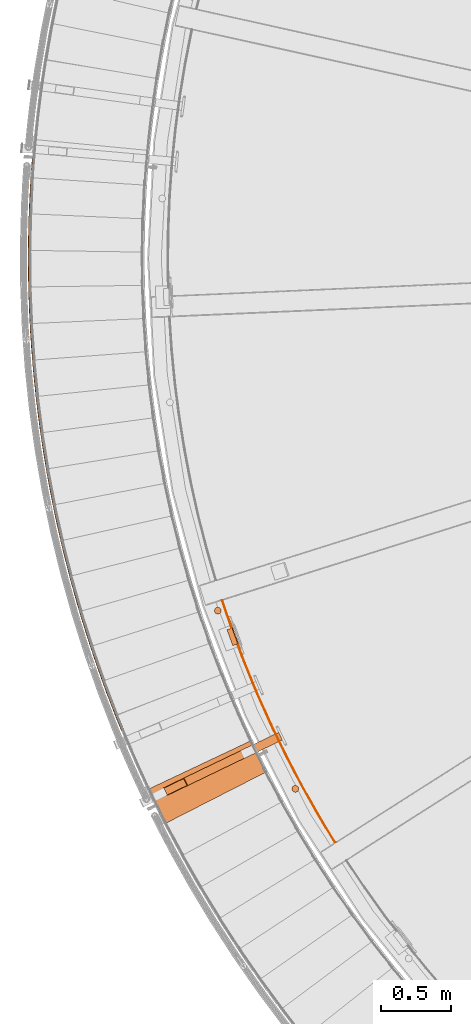
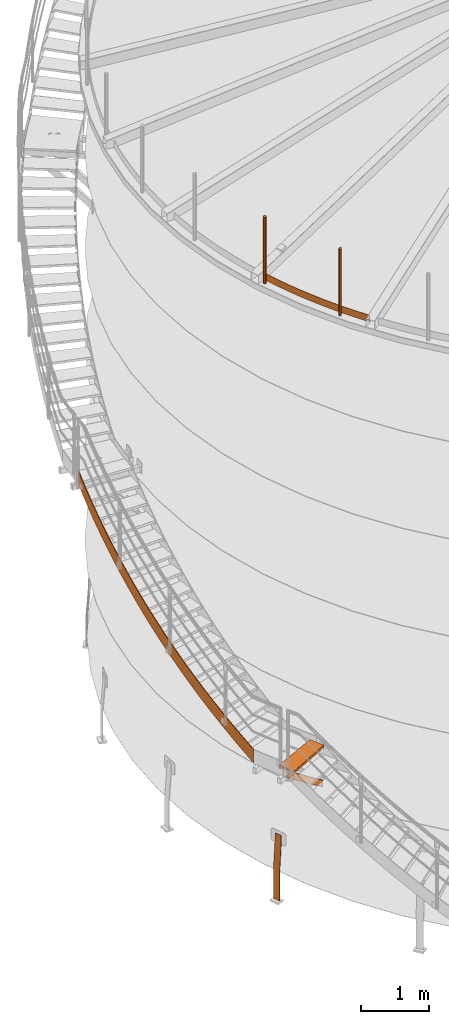
# One storey, part 10 of 126: 7 proxies.
"""IFC2X3 building model written with IfcOpenShell, lengths in millimetres."""

from ifc_helpers import new_model, si_unit, origin, origin_with_axes, place, context, project, spatial, faceted_brep, material, element, save


model = new_model("IFC2X3")

# Units and contexts
context_of_model_1 = context(None, 3, precision=0.1, world=origin())
context_of_model_2 = context(None, 3, precision=0.1, world=origin())
ifc_project = project(units=[si_unit("LENGTHUNIT", "METRE", prefix="MILLI"), si_unit("AREAUNIT", "SQUARE_METRE", prefix="CENTI"), si_unit("VOLUMEUNIT", "CUBIC_METRE", prefix="CENTI"), si_unit("MASSUNIT", "GRAM", prefix="KILO")], contexts=[context_of_model_1, context_of_model_2])

# Site, building, storey
site_placement = place(None, origin_with_axes())
site = spatial("IfcSite", under=ifc_project, at=site_placement, CompositionType="ELEMENT")
building_placement = place(site_placement, origin_with_axes())
building = spatial("IfcBuilding", under=site, at=building_placement, CompositionType="ELEMENT")
storey_placement = place(building_placement, origin_with_axes())
storey = spatial("IfcBuildingStorey", under=building, at=storey_placement, CompositionType="ELEMENT")

# Proxies
ifc_material_1 = material(Name="S235JRG2")
proxy_1_placement = place(storey_placement, origin_with_axes())
element("IfcBuildingElementProxy", 1, at=proxy_1_placement, inside=storey, material=ifc_material_1, context=context_of_model_2, shape_type="Brep", body=[
    faceted_brep([(-166.7085, 4662.1835, 2637.9555), (-157.4529, 4665.9697, 2637.8818), (-153.3509, 4656.0918, 2630.7481), (-162.2845, 4651.5301, 2630.2657), (-157.4529, 4665.9697, 2878.2856), (-153.3509, 4656.0918, 2871.1497), (-166.7085, 4662.1835, 2878.3209), (-162.2845, 4651.5301, 2870.6335), (-201.65, 4748.9075, 2700.2751), (-192.3548, 4752.5955, 2700.1807), (-192.3548, 4752.5955, 2940.5948), (-201.65, 4748.9075, 2940.6301), (-235.6711, 4835.9968, 2762.59), (-226.3373, 4839.5861, 2762.4843), (-226.3373, 4839.5861, 3002.9041), (-235.6711, 4835.9968, 3002.9394), (-268.7681, 4923.4414, 2824.9023), (-259.3968, 4926.9317, 2824.7904), (-259.3968, 4926.9317, 3065.2133), (-268.7681, 4923.4414, 3065.2486), (-300.9372, 5011.2316, 2887.2132), (-291.5295, 5014.6224, 2887.098), (-291.5295, 5014.6224, 3127.5226), (-300.9372, 5011.2316, 3127.5579), (-332.1748, 5099.3575, 2949.5234), (-322.7317, 5102.6486, 2949.4064), (-322.7317, 5102.6486, 3189.8318), (-332.1748, 5099.3575, 3189.8671), (-362.4774, 5187.8093, 3011.8331), (-353.0, 5191.0002, 3011.7151), (-353.0, 5191.0002, 3252.1411), (-362.4774, 5187.8093, 3252.1764), (-391.8416, 5276.577, 3074.1426), (-382.331, 5279.6674, 3074.0241), (-382.331, 5279.6674, 3314.4503), (-391.8416, 5276.577, 3314.4856), (-420.2642, 5365.6507, 3136.452), (-410.7213, 5368.6402, 3136.3332), (-410.7213, 5368.6402, 3376.7596), (-420.2642, 5365.6507, 3376.7949), (-447.7419, 5455.0205, 3198.7613), (-438.1679, 5457.9087, 3198.6424), (-438.1679, 5457.9087, 3439.0688), (-447.7419, 5455.0205, 3439.1041), (-474.2716, 5544.6761, 3261.0706), (-464.6676, 5547.4628, 3260.9516), (-464.6676, 5547.4628, 3501.3781), (-474.2716, 5544.6761, 3501.4134), (-499.8504, 5634.6077, 3323.3799), (-490.2175, 5637.2925, 3323.2608), (-490.2175, 5637.2925, 3563.6873), (-499.8504, 5634.6077, 3563.7226), (-524.4755, 5724.8052, 3385.6892), (-514.8146, 5727.3878, 3385.57), (-514.8146, 5727.3878, 3625.9966), (-524.4755, 5724.8052, 3626.0319), (-548.144, 5815.2583, 3447.9984), (-538.4563, 5817.7385, 3447.8793), (-538.4563, 5817.7385, 3688.3058), (-548.144, 5815.2583, 3688.3411), (-570.8532, 5905.957, 3510.3077), (-561.1398, 5908.3345, 3510.1885), (-561.1398, 5908.3345, 3750.615), (-570.8532, 5905.957, 3750.6504), (-592.6008, 5996.8911, 3572.6169), (-582.8627, 5999.1656, 3572.4978), (-582.8627, 5999.1656, 3812.9243), (-592.6008, 5996.8911, 3812.9596), (-613.3841, 6088.0505, 3634.9262), (-603.6225, 6090.2217, 3634.807), (-603.6225, 6090.2217, 3875.2335), (-613.3841, 6088.0505, 3875.2688), (-633.2009, 6179.4248, 3697.2354), (-623.4169, 6181.4925, 3697.1163), (-623.4169, 6181.4925, 3937.5428), (-633.2009, 6179.4248, 3937.5781), (-652.049, 6271.0038, 3759.5447), (-642.2436, 6272.9678, 3759.4255), (-642.2436, 6272.9678, 3999.852), (-652.049, 6271.0038, 3999.8873), (-669.9262, 6362.7773, 3821.8539), (-660.1006, 6364.6373, 3821.7347), (-660.1006, 6364.6373, 4062.1613), (-669.9262, 6362.7773, 4062.1966), (-686.8306, 6454.735, 3884.1631), (-676.9858, 6456.4909, 3884.044), (-676.9858, 6456.4909, 4124.4705), (-686.8306, 6454.735, 4124.5058), (-702.7601, 6546.8665, 3946.4724), (-692.8973, 6548.518, 3946.3532), (-692.8973, 6548.518, 4186.7798), (-702.7601, 6546.8665, 4186.8151), (-717.7132, 6639.1615, 4008.7816), (-707.8334, 6640.7085, 4008.6625), (-707.8334, 6640.7085, 4249.089), (-717.7132, 6639.1615, 4249.1243), (-731.688, 6731.6097, 4071.0909), (-721.7924, 6733.052, 4070.9717), (-721.7924, 6733.052, 4311.3983), (-731.688, 6731.6097, 4311.4336), (-744.683, 6824.2008, 4133.4001), (-734.7727, 6825.5382, 4133.281), (-734.7727, 6825.5382, 4373.7075), (-744.683, 6824.2008, 4373.7428), (-756.6968, 6916.9242, 4195.7094), (-746.7729, 6918.1566, 4195.5902), (-746.7729, 6918.1566, 4436.0168), (-756.6968, 6916.9242, 4436.0521), (-767.728, 7009.7697, 4258.0186), (-757.7916, 7010.8969, 4257.8995), (-757.7916, 7010.8969, 4498.326), (-767.728, 7009.7697, 4498.3613), (-777.7754, 7102.7268, 4320.3279), (-767.8276, 7103.7487, 4320.2087), (-767.8276, 7103.7487, 4560.6353), (-777.7754, 7102.7268, 4560.6706), (-786.8378, 7195.785, 4382.6371), (-776.8797, 7196.7016, 4382.518), (-776.8797, 7196.7016, 4622.9445), (-786.8378, 7195.785, 4622.9798), (-794.9142, 7288.9341, 4444.9464), (-784.947, 7289.7451, 4444.8272), (-784.947, 7289.7451, 4685.2538), (-794.9142, 7288.9341, 4685.2891), (-802.0037, 7382.1634, 4507.2556), (-792.0285, 7382.8688, 4507.1365), (-792.0285, 7382.8688, 4747.563), (-802.0037, 7382.1634, 4747.5983), (-808.1056, 7475.4626, 4569.5649), (-798.1235, 7476.0623, 4569.4457), (-798.1235, 7476.0623, 4809.8723), (-808.1056, 7475.4626, 4809.9076), (-813.2191, 7568.8211, 4631.8741), (-803.2312, 7569.3152, 4631.755), (-803.2312, 7569.3152, 4872.1815), (-813.2191, 7568.8211, 4872.2168), (-817.3437, 7662.2286, 4694.1834), (-807.3511, 7662.6168, 4694.0642), (-807.3511, 7662.6168, 4934.4908), (-817.3437, 7662.2286, 4934.5261), (-820.4789, 7755.6745, 4756.4926), (-810.4827, 7755.9569, 4756.3735), (-810.4827, 7755.9569, 4996.8), (-820.4789, 7755.6745, 4996.8353), (-822.6243, 7849.1484, 4818.8019), (-812.6257, 7849.3249, 4818.6827), (-812.6257, 7849.3249, 5059.1092), (-822.6243, 7849.1484, 5059.1446), (-823.7798, 7942.6397, 4881.1111), (-813.7799, 7942.7104, 4880.992), (-813.7799, 7942.7104, 5121.4185), (-823.7798, 7942.6397, 5121.4538), (-823.9451, 8036.1381, 4943.4204), (-813.945, 8036.1028, 4943.3012), (-813.945, 8036.1028, 5183.7277), (-823.9451, 8036.1381, 5183.763), (-823.1203, 8129.633, 5005.7296), (-813.1212, 8129.4918, 5005.6105), (-813.1212, 8129.4918, 5246.037), (-823.1203, 8129.633, 5246.0723), (-821.3054, 8223.1138, 5068.0389), (-811.3084, 8222.8668, 5067.9197), (-811.3084, 8222.8668, 5308.3462), (-821.3054, 8223.1138, 5308.3815), (-818.5008, 8316.5703, 5130.3481), (-808.5068, 8316.2174, 5130.2289), (-808.5068, 8316.2174, 5370.6555), (-818.5008, 8316.5703, 5370.6908), (-814.7065, 8409.9917, 5192.6573), (-804.7169, 8409.533, 5192.5382), (-804.7169, 8409.533, 5432.9647), (-814.7065, 8409.9917, 5433.0), (-809.9232, 8503.3678, 5254.9666), (-799.939, 8502.8033, 5254.8474), (-799.939, 8502.8033, 5495.274), (-809.9232, 8503.3678, 5495.3093), (-804.1514, 8596.688, 5317.2758), (-794.1737, 8596.0178, 5317.1567), (-794.1737, 8596.0178, 5557.5832), (-804.1514, 8596.688, 5557.6185), (-797.3916, 8689.9418, 5379.5851), (-787.4216, 8689.166, 5379.4659), (-787.4216, 8689.166, 5619.8925), (-797.3916, 8689.9418, 5619.9278), (-794.5665, 8723.9204, 5402.3072), (-784.5865, 8723.2653, 5402.2947), (-784.5865, 8723.2653, 5642.7212), (-794.5665, 8723.9204, 5642.6499)], [[[0, 1, 2, 3]], [[1, 4, 5, 2]], [[4, 6, 7, 5]], [[0, 3, 7, 6]], [[0, 8, 9, 1]], [[1, 9, 10, 4]], [[4, 10, 11, 6]], [[6, 11, 8, 0]], [[8, 12, 13, 9]], [[9, 13, 14, 10]], [[10, 14, 15, 11]], [[11, 15, 12, 8]], [[12, 16, 17, 13]], [[13, 17, 18, 14]], [[14, 18, 19, 15]], [[15, 19, 16, 12]], [[16, 20, 21, 17]], [[17, 21, 22, 18]], [[18, 22, 23, 19]], [[19, 23, 20, 16]], [[20, 24, 25, 21]], [[21, 25, 26, 22]], [[22, 26, 27, 23]], [[23, 27, 24, 20]], [[24, 28, 29, 25]], [[25, 29, 30, 26]], [[26, 30, 31, 27]], [[27, 31, 28, 24]], [[28, 32, 33, 29]], [[29, 33, 34, 30]], [[30, 34, 35, 31]], [[31, 35, 32, 28]], [[32, 36, 37, 33]], [[33, 37, 38, 34]], [[34, 38, 39, 35]], [[35, 39, 36, 32]], [[36, 40, 41, 37]], [[37, 41, 42, 38]], [[38, 42, 43, 39]], [[39, 43, 40, 36]], [[40, 44, 45, 41]], [[41, 45, 46, 42]], [[42, 46, 47, 43]], [[43, 47, 44, 40]], [[44, 48, 49, 45]], [[45, 49, 50, 46]], [[46, 50, 51, 47]], [[47, 51, 48, 44]], [[48, 52, 53, 49]], [[49, 53, 54, 50]], [[50, 54, 55, 51]], [[51, 55, 52, 48]], [[52, 56, 57, 53]], [[53, 57, 58, 54]], [[54, 58, 59, 55]], [[55, 59, 56, 52]], [[56, 60, 61, 57]], [[57, 61, 62, 58]], [[58, 62, 63, 59]], [[59, 63, 60, 56]], [[60, 64, 65, 61]], [[61, 65, 66, 62]], [[62, 66, 67, 63]], [[63, 67, 64, 60]], [[64, 68, 69, 65]], [[65, 69, 70, 66]], [[66, 70, 71, 67]], [[67, 71, 68, 64]], [[68, 72, 73, 69]], [[69, 73, 74, 70]], [[70, 74, 75, 71]], [[71, 75, 72, 68]], [[72, 76, 77, 73]], [[73, 77, 78, 74]], [[74, 78, 79, 75]], [[75, 79, 76, 72]], [[76, 80, 81, 77]], [[77, 81, 82, 78]], [[78, 82, 83, 79]], [[79, 83, 80, 76]], [[80, 84, 85, 81]], [[81, 85, 86, 82]], [[82, 86, 87, 83]], [[83, 87, 84, 80]], [[84, 88, 89, 85]], [[85, 89, 90, 86]], [[86, 90, 91, 87]], [[87, 91, 88, 84]], [[88, 92, 93, 89]], [[89, 93, 94, 90]], [[90, 94, 95, 91]], [[91, 95, 92, 88]], [[92, 96, 97, 93]], [[93, 97, 98, 94]], [[94, 98, 99, 95]], [[95, 99, 96, 92]], [[96, 100, 101, 97]], [[97, 101, 102, 98]], [[98, 102, 103, 99]], [[99, 103, 100, 96]], [[100, 104, 105, 101]], [[101, 105, 106, 102]], [[102, 106, 107, 103]], [[103, 107, 104, 100]], [[104, 108, 109, 105]], [[105, 109, 110, 106]], [[106, 110, 111, 107]], [[107, 111, 108, 104]], [[108, 112, 113, 109]], [[109, 113, 114, 110]], [[110, 114, 115, 111]], [[111, 115, 112, 108]], [[112, 116, 117, 113]], [[113, 117, 118, 114]], [[114, 118, 119, 115]], [[115, 119, 116, 112]], [[116, 120, 121, 117]], [[117, 121, 122, 118]], [[118, 122, 123, 119]], [[119, 123, 120, 116]], [[120, 124, 125, 121]], [[121, 125, 126, 122]], [[122, 126, 127, 123]], [[123, 127, 124, 120]], [[124, 128, 129, 125]], [[125, 129, 130, 126]], [[126, 130, 131, 127]], [[127, 131, 128, 124]], [[128, 132, 133, 129]], [[129, 133, 134, 130]], [[130, 134, 135, 131]], [[131, 135, 132, 128]], [[132, 136, 137, 133]], [[133, 137, 138, 134]], [[134, 138, 139, 135]], [[135, 139, 136, 132]], [[136, 140, 141, 137]], [[137, 141, 142, 138]], [[138, 142, 143, 139]], [[139, 143, 140, 136]], [[140, 144, 145, 141]], [[141, 145, 146, 142]], [[142, 146, 147, 143]], [[143, 147, 144, 140]], [[144, 148, 149, 145]], [[145, 149, 150, 146]], [[146, 150, 151, 147]], [[147, 151, 148, 144]], [[148, 152, 153, 149]], [[149, 153, 154, 150]], [[150, 154, 155, 151]], [[151, 155, 152, 148]], [[152, 156, 157, 153]], [[153, 157, 158, 154]], [[154, 158, 159, 155]], [[155, 159, 156, 152]], [[156, 160, 161, 157]], [[157, 161, 162, 158]], [[158, 162, 163, 159]], [[159, 163, 160, 156]], [[160, 164, 165, 161]], [[161, 165, 166, 162]], [[162, 166, 167, 163]], [[163, 167, 164, 160]], [[164, 168, 169, 165]], [[165, 169, 170, 166]], [[166, 170, 171, 167]], [[167, 171, 168, 164]], [[168, 172, 173, 169]], [[169, 173, 174, 170]], [[170, 174, 175, 171]], [[171, 175, 172, 168]], [[172, 176, 177, 173]], [[173, 177, 178, 174]], [[174, 178, 179, 175]], [[175, 179, 176, 172]], [[176, 180, 181, 177]], [[177, 181, 182, 178]], [[178, 182, 183, 179]], [[179, 183, 180, 176]], [[180, 184, 185, 181]], [[181, 185, 186, 182]], [[182, 186, 187, 183]], [[180, 183, 187, 184]], [[2, 5, 7, 3]], [[184, 187, 186, 185]]]),
])
ifc_material_2 = material(Name="STAHL")
proxy_2_placement = place(storey_placement, origin_with_axes())
element("IfcBuildingElementProxy", 2, at=proxy_2_placement, inside=storey, material=ifc_material_2, Name="profile", context=context_of_model_2, shape_type="Brep", body=[
    faceted_brep([(623.3, 5378.6, 651.1), (624.2, 5376.2, 654.1), (631.7, 5379.0, 654.1), (630.9, 5381.3, 651.1), (622.7, 5380.3, 647.7), (630.2, 5383.0, 647.7), (622.3, 5381.4, 643.9), (629.8, 5384.1, 643.9), (586.5, 5368.7, -500.0), (586.5, 5368.7, 0.0), (622.2, 5381.7, 540.0), (622.2, 5381.7, 640.0), (629.7, 5384.5, 640.0), (629.7, 5384.5, 540.0), (594.0, 5371.5, 0.0), (594.0, 5371.5, -500.0), (669.6, 5274.9, 651.1), (668.7, 5277.2, 654.1), (661.2, 5274.5, 654.1), (662.1, 5272.1, 651.1), (662.7, 5270.4, 647.7), (670.2, 5273.1, 647.7), (663.1, 5269.3, 643.9), (670.6, 5272.1, 643.9), (627.5, 5256.0, 0.0), (627.5, 5256.0, -500.0), (635.0, 5258.7, -500.0), (635.0, 5258.7, 0.0), (670.7, 5271.7, 540.0), (670.7, 5271.7, 640.0), (663.2, 5269.0, 640.0), (663.2, 5269.0, 540.0), (657.7, 5284.1, 659.6), (665.2, 5286.8, 659.6), (663.9, 5290.5, 660.0), (636.5, 5365.7, 660.0), (635.2, 5369.3, 659.6), (627.7, 5366.6, 659.6), (629.0, 5362.9, 660.0), (656.4, 5287.8, 660.0), (659.0, 5280.6, 658.5), (666.5, 5283.3, 658.5), (660.2, 5277.3, 656.6), (667.7, 5280.1, 656.6), (626.4, 5370.1, 658.5), (633.9, 5372.9, 658.5), (625.2, 5373.4, 656.6), (632.7, 5376.1, 656.6)], [[[0, 1, 2, 3]], [[4, 0, 3, 5]], [[6, 4, 5, 7]], [[8, 9, 10, 11, 6, 7, 12, 13, 14, 15]], [[16, 17, 18, 19]], [[16, 19, 20, 21]], [[21, 20, 22, 23]], [[24, 25, 26, 27, 28, 29, 23, 22, 30, 31]], [[32, 33, 34, 35, 36, 37, 38, 39]], [[33, 32, 40, 41]], [[41, 40, 42, 43]], [[43, 42, 18, 17]], [[44, 37, 36, 45]], [[46, 44, 45, 47]], [[46, 47, 2, 1]], [[25, 24, 31, 30, 22, 20, 19, 18, 42, 40, 32, 39, 38, 37, 44, 46, 1, 0, 4, 6, 11, 10, 9, 8]], [[27, 26, 15, 14, 13, 12, 7, 5, 3, 2, 47, 45, 36, 35, 34, 33, 41, 43, 17, 16, 21, 23, 29, 28]], [[25, 8, 15, 26]]]),
])
proxy_3_placement = place(storey_placement, origin_with_axes())
element("IfcBuildingElementProxy", 3, at=proxy_3_placement, inside=storey, material=ifc_material_2, Name="profile", context=context_of_model_2, shape_type="Brep", body=[
    faceted_brep([(532.3, 5526.5, 11706.0), (532.3, 5526.5, 10506.0), (526.8, 5528.5, 10506.0), (526.8, 5528.5, 11706.0), (521.0, 5529.0, 10506.0), (521.0, 5529.0, 11706.0), (515.2, 5528.2, 10506.0), (515.2, 5528.2, 11706.0), (509.8, 5526.0, 10506.0), (509.8, 5526.0, 11706.0), (505.1, 5522.6, 10506.0), (505.1, 5522.6, 11706.0), (501.4, 5518.1, 10506.0), (501.4, 5518.1, 11706.0), (498.8, 5512.9, 10506.0), (498.8, 5512.9, 11706.0), (497.5, 5507.2, 10506.0), (497.5, 5507.2, 11706.0), (497.7, 5501.4, 10506.0), (497.7, 5501.4, 11706.0), (499.2, 5495.8, 10506.0), (499.2, 5495.8, 11706.0), (502.0, 5490.7, 10506.0), (502.0, 5490.7, 11706.0), (506.0, 5486.4, 10506.0), (506.0, 5486.4, 11706.0), (510.9, 5483.2, 11706.0), (510.9, 5483.2, 10506.0), (516.4, 5481.3, 10506.0), (516.4, 5481.3, 11706.0), (522.2, 5480.7, 10506.0), (522.2, 5480.7, 11706.0), (527.9, 5481.6, 10506.0), (527.9, 5481.6, 11706.0), (533.3, 5483.8, 10506.0), (533.3, 5483.8, 11706.0), (538.0, 5487.2, 10506.0), (538.0, 5487.2, 11706.0), (541.8, 5491.7, 10506.0), (541.8, 5491.7, 11706.0), (544.4, 5496.9, 10506.0), (544.4, 5496.9, 11706.0), (545.6, 5502.6, 10506.0), (545.6, 5502.6, 11706.0), (545.5, 5508.4, 10506.0), (545.5, 5508.4, 11706.0), (543.9, 5514.0, 10506.0), (543.9, 5514.0, 11706.0), (541.1, 5519.1, 10506.0), (541.1, 5519.1, 11706.0), (537.2, 5523.3, 10506.0), (537.2, 5523.3, 11706.0)], [[[0, 1, 2, 3]], [[3, 2, 4, 5]], [[5, 4, 6, 7]], [[7, 6, 8, 9]], [[9, 8, 10, 11]], [[11, 10, 12, 13]], [[13, 12, 14, 15]], [[15, 14, 16, 17]], [[17, 16, 18, 19]], [[19, 18, 20, 21]], [[21, 20, 22, 23]], [[23, 22, 24, 25]], [[26, 25, 24, 27]], [[26, 27, 28, 29]], [[29, 28, 30, 31]], [[31, 30, 32, 33]], [[33, 32, 34, 35]], [[35, 34, 36, 37]], [[37, 36, 38, 39]], [[39, 38, 40, 41]], [[41, 40, 42, 43]], [[43, 42, 44, 45]], [[45, 44, 46, 47]], [[47, 46, 48, 49]], [[49, 48, 50, 51]], [[51, 50, 1, 0]], [[31, 33, 35, 37, 39, 41, 43, 45, 47, 49, 51, 0, 3, 5, 7, 9, 11, 13, 15, 17, 19, 21, 23, 25, 26, 29]], [[30, 28, 27, 24, 22, 20, 18, 16, 14, 12, 10, 8, 6, 4, 2, 1, 50, 48, 46, 44, 42, 40, 38, 36, 34, 32]]]),
])
proxy_4_placement = place(storey_placement, origin_with_axes())
element("IfcBuildingElementProxy", 4, at=proxy_4_placement, inside=storey, material=ifc_material_2, Name="profile", context=context_of_model_2, shape_type="Brep", body=[
    faceted_brep([(1078.3, 4262.7, 11706.0), (1078.3, 4262.7, 10506.0), (1072.6, 4263.6, 10506.0), (1072.6, 4263.6, 11706.0), (1066.8, 4263.2, 10506.0), (1066.8, 4263.2, 11706.0), (1061.2, 4261.3, 10506.0), (1061.2, 4261.3, 11706.0), (1056.3, 4258.2, 10506.0), (1056.3, 4258.2, 11706.0), (1052.3, 4254.0, 10506.0), (1052.3, 4254.0, 11706.0), (1049.3, 4249.0, 10506.0), (1049.3, 4249.0, 11706.0), (1047.7, 4243.4, 10506.0), (1047.7, 4243.4, 11706.0), (1047.5, 4237.6, 10506.0), (1047.5, 4237.6, 11706.0), (1048.6, 4231.9, 10506.0), (1048.6, 4231.9, 11706.0), (1051.1, 4226.6, 10506.0), (1051.1, 4226.6, 11706.0), (1054.8, 4222.1, 10506.0), (1054.8, 4222.1, 11706.0), (1059.4, 4218.6, 10506.0), (1059.4, 4218.6, 11706.0), (1064.8, 4216.3, 11706.0), (1064.8, 4216.3, 10506.0), (1070.5, 4215.4, 10506.0), (1070.5, 4215.4, 11706.0), (1076.3, 4215.8, 10506.0), (1076.3, 4215.8, 11706.0), (1081.8, 4217.6, 10506.0), (1081.8, 4217.6, 11706.0), (1086.8, 4220.7, 10506.0), (1086.8, 4220.7, 11706.0), (1090.8, 4224.9, 10506.0), (1090.8, 4224.9, 11706.0), (1093.7, 4230.0, 10506.0), (1093.7, 4230.0, 11706.0), (1095.4, 4235.6, 10506.0), (1095.4, 4235.6, 11706.0), (1095.6, 4241.4, 10506.0), (1095.6, 4241.4, 11706.0), (1094.5, 4247.1, 10506.0), (1094.5, 4247.1, 11706.0), (1092.0, 4252.3, 10506.0), (1092.0, 4252.3, 11706.0), (1088.3, 4256.9, 10506.0), (1088.3, 4256.9, 11706.0), (1083.6, 4260.4, 10506.0), (1083.6, 4260.4, 11706.0)], [[[0, 1, 2, 3]], [[3, 2, 4, 5]], [[5, 4, 6, 7]], [[7, 6, 8, 9]], [[9, 8, 10, 11]], [[11, 10, 12, 13]], [[13, 12, 14, 15]], [[15, 14, 16, 17]], [[17, 16, 18, 19]], [[19, 18, 20, 21]], [[21, 20, 22, 23]], [[23, 22, 24, 25]], [[26, 25, 24, 27]], [[26, 27, 28, 29]], [[29, 28, 30, 31]], [[31, 30, 32, 33]], [[33, 32, 34, 35]], [[35, 34, 36, 37]], [[37, 36, 38, 39]], [[39, 38, 40, 41]], [[41, 40, 42, 43]], [[43, 42, 44, 45]], [[45, 44, 46, 47]], [[47, 46, 48, 49]], [[49, 48, 50, 51]], [[51, 50, 1, 0]], [[29, 31, 33, 35, 37, 39, 41, 43, 45, 47, 49, 51, 0, 3, 5, 7, 9, 11, 13, 15, 17, 19, 21, 23, 25, 26]], [[28, 27, 24, 22, 20, 18, 16, 14, 12, 10, 8, 6, 4, 2, 1, 50, 48, 46, 44, 42, 40, 38, 36, 34, 32, 30]]]),
])
proxy_5_placement = place(storey_placement, origin_with_axes())
element("IfcBuildingElementProxy", 5, at=proxy_5_placement, inside=storey, material=ifc_material_2, Name="profile", context=context_of_model_2, shape_type="Brep", body=[
    faceted_brep([(1352.7, 3856.5, 10516.0), (1352.7, 3856.5, 10636.0), (1229.9, 4060.3, 10636.0), (1113.3, 4267.7, 10636.0), (1003.0, 4478.5, 10636.0), (899.3, 4692.6, 10636.0), (802.0, 4909.8, 10636.0), (711.4, 5129.8, 10636.0), (627.5, 5352.4, 10636.0), (550.4, 5577.5, 10636.0), (550.4, 5577.5, 10516.0), (627.5, 5352.4, 10516.0), (711.4, 5129.8, 10516.0), (802.0, 4909.8, 10516.0), (899.3, 4692.6, 10516.0), (1003.0, 4478.5, 10516.0), (1113.3, 4267.7, 10516.0), (1229.9, 4060.3, 10516.0), (1356.9, 3859.2, 10636.0), (1234.2, 4062.8, 10636.0), (1117.7, 4270.1, 10636.0), (1007.5, 4480.8, 10636.0), (903.8, 4694.7, 10636.0), (806.6, 4911.8, 10636.0), (716.1, 5131.6, 10636.0), (632.2, 5354.1, 10636.0), (555.2, 5579.0, 10636.0), (1356.9, 3859.2, 10516.0), (1234.2, 4062.8, 10516.0), (1117.7, 4270.1, 10516.0), (1007.5, 4480.8, 10516.0), (903.8, 4694.7, 10516.0), (806.6, 4911.8, 10516.0), (716.1, 5131.6, 10516.0), (632.2, 5354.1, 10516.0), (555.2, 5579.0, 10516.0)], [[[0, 1, 2, 3, 4, 5, 6, 7, 8, 9, 10, 11, 12, 13, 14, 15, 16, 17]], [[1, 18, 19, 20, 21, 22, 23, 24, 25, 26, 9, 8, 7, 6, 5, 4, 3, 2]], [[18, 27, 28, 29, 30, 31, 32, 33, 34, 35, 26, 25, 24, 23, 22, 21, 20, 19]], [[0, 17, 16, 15, 14, 13, 12, 11, 10, 35, 34, 33, 32, 31, 30, 29, 28, 27]], [[18, 1, 0, 27]], [[26, 35, 10, 9]]]),
])
proxy_6_placement = place(storey_placement, origin_with_axes())
element("IfcBuildingElementProxy", 6, at=proxy_6_placement, inside=storey, material=ifc_material_1, context=context_of_model_2, shape_type="Brep", body=[
    faceted_brep([(158.3146, 4191.1272, 2521.25), (132.2714, 4245.1804, 2521.25), (953.3428, 4640.7767, 1834.459), (979.3859, 4586.7235, 1834.459), (281.9666, 4317.3043, 2521.25), (953.3428, 4640.7767, 1959.6725), (308.0097, 4263.251, 2521.25), (979.3859, 4586.7235, 1959.6725), (161.5033, 4195.9936, 2521.25), (302.2167, 4263.79, 2521.25), (978.0838, 4589.4261, 1955.9161), (978.0838, 4589.4261, 1838.2154), (278.7779, 4312.4379, 2521.25), (954.6449, 4638.0741, 1955.9161), (138.0644, 4244.6415, 2521.25), (954.6449, 4638.0741, 1838.2154)], [[[0, 1, 2, 3]], [[1, 4, 5, 2]], [[4, 6, 7, 5]], [[0, 3, 7, 6]], [[8, 9, 10, 11]], [[9, 12, 13, 10]], [[12, 14, 15, 13]], [[8, 11, 15, 14]], [[1, 0, 6, 4], [8, 14, 12, 9]], [[3, 2, 5, 7], [10, 13, 15, 11]]]),
])
ifc_material_3 = material(Name="HOLZ")
proxy_7_placement = place(storey_placement, origin_with_axes())
element("IfcBuildingElementProxy", 7, at=proxy_7_placement, inside=storey, material=ifc_material_3, context=context_of_model_2, shape_type="Brep", body=[
    faceted_brep([(32.4002, 4239.7453, 2771.3), (43.0051, 4217.3718, 2771.3), (53.6728, 4195.0281, 2771.3), (64.4032, 4172.7145, 2771.3), (75.1962, 4150.4311, 2771.3), (86.0517, 4128.1781, 2771.3), (96.9697, 4105.9557, 2771.3), (107.9501, 4083.764, 2771.3), (118.9927, 4061.6032, 2771.3), (130.0975, 4039.4736, 2771.3), (141.2644, 4017.3752, 2771.3), (152.4933, 3995.3082, 2771.3), (864.9811, 4359.1229, 2771.3), (853.7532, 4381.1957, 2771.3), (842.5934, 4403.3031, 2771.3), (831.502, 4425.4448, 2771.3), (820.479, 4447.6207, 2771.3), (809.5246, 4469.8305, 2771.3), (798.6389, 4492.0741, 2771.3), (787.8219, 4514.3511, 2771.3), (777.0738, 4536.6615, 2771.3), (766.3946, 4559.005, 2771.3), (755.7845, 4581.3813, 2771.3), (32.4002, 4239.7453, 2731.3), (755.7845, 4581.3813, 2731.3), (766.3946, 4559.005, 2731.3), (777.0738, 4536.6615, 2731.3), (787.8219, 4514.3511, 2731.3), (798.6389, 4492.0741, 2731.3), (809.5246, 4469.8305, 2731.3), (820.479, 4447.6207, 2731.3), (831.502, 4425.4448, 2731.3), (842.5934, 4403.3031, 2731.3), (853.7532, 4381.1957, 2731.3), (864.9811, 4359.1229, 2731.3), (152.4933, 3995.3082, 2731.3), (141.2644, 4017.3752, 2731.3), (130.0975, 4039.4736, 2731.3), (118.9927, 4061.6032, 2731.3), (107.9501, 4083.764, 2731.3), (96.9697, 4105.9557, 2731.3), (86.0517, 4128.1781, 2731.3), (75.1962, 4150.4311, 2731.3), (64.4032, 4172.7145, 2731.3), (53.6728, 4195.0281, 2731.3), (43.0051, 4217.3718, 2731.3)], [[[0, 1, 2, 3, 4, 5, 6, 7, 8, 9, 10, 11, 12, 13, 14, 15, 16, 17, 18, 19, 20, 21, 22]], [[23, 24, 25, 26, 27, 28, 29, 30, 31, 32, 33, 34, 35, 36, 37, 38, 39, 40, 41, 42, 43, 44, 45]], [[0, 23, 45, 1]], [[1, 45, 44, 2]], [[2, 44, 43, 3]], [[3, 43, 42, 4]], [[4, 42, 41, 5]], [[5, 41, 40, 6]], [[6, 40, 39, 7]], [[7, 39, 38, 8]], [[8, 38, 37, 9]], [[9, 37, 36, 10]], [[10, 36, 35, 11]], [[11, 35, 34, 12]], [[12, 34, 33, 13]], [[13, 33, 32, 14]], [[14, 32, 31, 15]], [[15, 31, 30, 16]], [[16, 30, 29, 17]], [[17, 29, 28, 18]], [[18, 28, 27, 19]], [[19, 27, 26, 20]], [[20, 26, 25, 21]], [[21, 25, 24, 22]], [[22, 24, 23, 0]]]),
])

save(model, "model.ifc")
